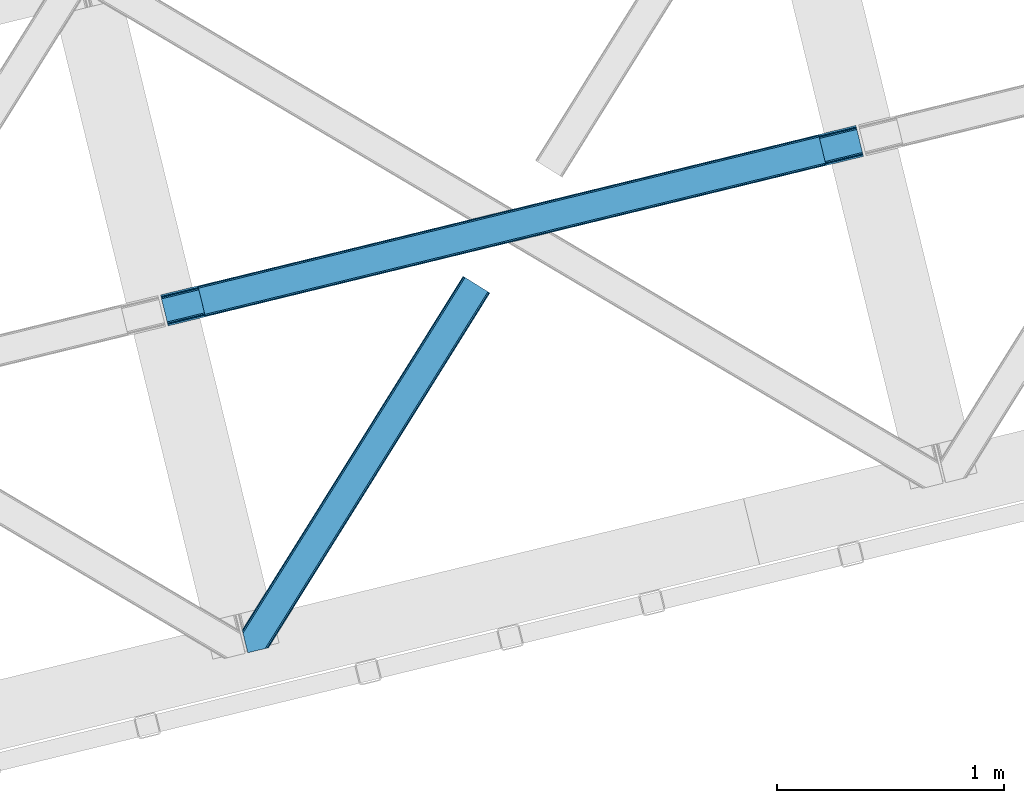
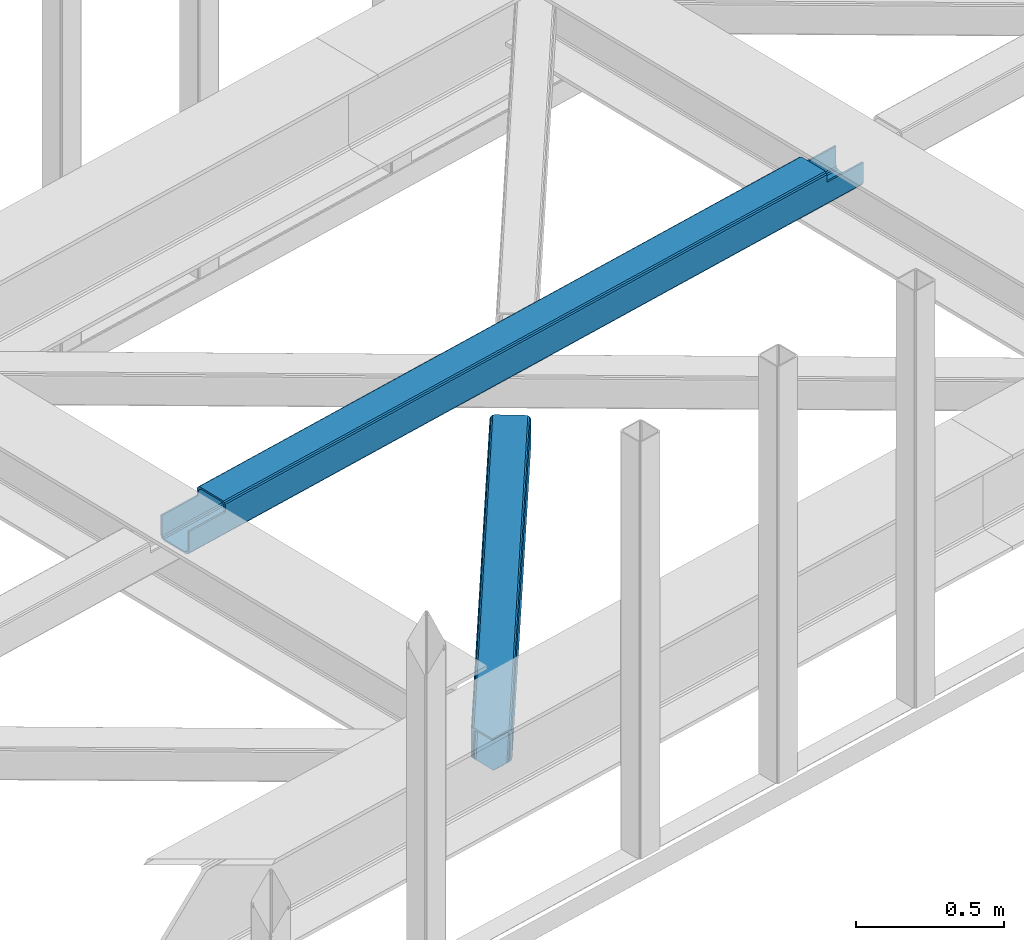
# One storey, part 42 of 66: 1 beam, 1 member.
"""IFC4 building model written with IfcOpenShell, lengths in millimetres."""

from ifc_helpers import new_model, entity, si_unit, converted_unit, derived_unit, direction, frame, origin, place, context, subcontext, project, spatial, triangles, polygons, material, type_object, element, save


model = new_model("IFC4")

# Units and contexts
model_context = context("Model", 3, precision=0.01, world=origin(), true_north=direction((6.12303176911189e-17, 1.0)))
plan_context = context("Plan", 3, precision=0.01, world=origin(), true_north=direction((6.12303176911189e-17, 1.0)))
body_context = subcontext(model_context, "Body", "Model", "MODEL_VIEW")
ifc_project = project(units=[si_unit("LENGTHUNIT", "METRE", prefix="MILLI"), si_unit("AREAUNIT", "SQUARE_METRE"), si_unit("VOLUMEUNIT", "CUBIC_METRE"), converted_unit("PLANEANGLEUNIT", "DEGREE", entity("IfcRatioMeasure", 0.0174532925199433), si_unit("PLANEANGLEUNIT", "RADIAN"), dimensions=[0, 0, 0, 0, 0, 0, 0]), si_unit("MASSUNIT", "GRAM", prefix="KILO"), derived_unit("MASSDENSITYUNIT", [(si_unit("MASSUNIT", "GRAM", prefix="KILO"), 1), (si_unit("LENGTHUNIT", "METRE"), -3)]), derived_unit("MOMENTOFINERTIAUNIT", [(si_unit("LENGTHUNIT", "METRE"), 4)]), si_unit("TIMEUNIT", "SECOND"), si_unit("FREQUENCYUNIT", "HERTZ"), si_unit("THERMODYNAMICTEMPERATUREUNIT", "DEGREE_CELSIUS"), derived_unit("THERMALTRANSMITTANCEUNIT", [(si_unit("MASSUNIT", "GRAM", prefix="KILO"), 1), (si_unit("THERMODYNAMICTEMPERATUREUNIT", "KELVIN"), -1), (si_unit("TIMEUNIT", "SECOND"), -3)]), derived_unit("VOLUMETRICFLOWRATEUNIT", [(si_unit("LENGTHUNIT", "METRE"), 3), (si_unit("TIMEUNIT", "SECOND"), -1)]), derived_unit("MASSFLOWRATEUNIT", [(si_unit("MASSUNIT", "GRAM", prefix="KILO"), 1), (si_unit("TIMEUNIT", "SECOND"), -1)]), derived_unit("ROTATIONALFREQUENCYUNIT", [(si_unit("TIMEUNIT", "SECOND"), -1)]), si_unit("ELECTRICCURRENTUNIT", "AMPERE"), si_unit("ELECTRICVOLTAGEUNIT", "VOLT"), si_unit("POWERUNIT", "WATT"), si_unit("FORCEUNIT", "NEWTON", prefix="KILO"), si_unit("ILLUMINANCEUNIT", "LUX"), si_unit("LUMINOUSFLUXUNIT", "LUMEN"), si_unit("LUMINOUSINTENSITYUNIT", "CANDELA"), derived_unit("USERDEFINED", [(si_unit("MASSUNIT", "GRAM", prefix="KILO"), -1), (si_unit("LENGTHUNIT", "METRE"), -2), (si_unit("TIMEUNIT", "SECOND"), 3), (si_unit("LUMINOUSFLUXUNIT", "LUMEN"), 1)]), derived_unit("LINEARVELOCITYUNIT", [(si_unit("LENGTHUNIT", "METRE"), 1), (si_unit("TIMEUNIT", "SECOND"), -1)]), si_unit("PRESSUREUNIT", "PASCAL"), derived_unit("USERDEFINED", [(si_unit("LENGTHUNIT", "METRE"), -2), (si_unit("MASSUNIT", "GRAM", prefix="KILO"), 1), (si_unit("TIMEUNIT", "SECOND"), -2)]), derived_unit("LINEARFORCEUNIT", [(si_unit("MASSUNIT", "GRAM", prefix="KILO"), 1), (si_unit("LENGTHUNIT", "METRE"), 1), (si_unit("TIMEUNIT", "SECOND"), -2), (si_unit("LENGTHUNIT", "METRE"), -1)]), derived_unit("PLANARFORCEUNIT", [(si_unit("MASSUNIT", "GRAM", prefix="KILO"), 1), (si_unit("LENGTHUNIT", "METRE"), 1), (si_unit("TIMEUNIT", "SECOND"), -2), (si_unit("LENGTHUNIT", "METRE"), -2)])], contexts=[model_context, plan_context])

# Site, building, storey
site_placement = place(None, origin())
site = spatial("IfcSite", under=ifc_project, at=site_placement, CompositionType="ELEMENT")
building_placement = place(site_placement, origin())
building = spatial("IfcBuilding", under=site, at=building_placement, CompositionType="ELEMENT")
storey_placement = place(building_placement, frame((0.0, 0.0, 19800.0)))
storey = spatial("IfcBuildingStorey", under=building, at=storey_placement, Name="06", CompositionType="ELEMENT", Elevation=19800.0)

# Beam
ifc_material = material(Name="Metal painted (White)")
beam_type = type_object("IfcBeamType", PredefinedType="BEAM")
beam_placement = place(storey_placement, frame((-23668.08, 13370.6, 3967.02)))
element("IfcBeam", 1, at=beam_placement, inside=storey, type_object=beam_type, material=ifc_material, ObjectType="Steel Beam", PredefinedType="BEAM", context=body_context, shape_type="Tessellation", body=[
    polygons([(31.1823923917571, 8.09507685196108, 17.8030399336114), (31.4978703677187, 6.80086440699217, 24.4999999999988), (3089.94374939707, 752.329405140572, 24.4999999999988), (3089.62827142112, 753.623617585543, 17.8030399336114), (30.2839871259035, 11.7806820741864, 12.1256313292298), (3088.72986615527, 757.309222807771, 12.1256313292298), (28.9394286278234, 17.2965800886753, 8.33210818105214), (3087.38530765718, 762.82512082226, 8.33210818105214), (27.3534137403861, 23.8030254244683, 7.00000000000274), (3085.79929276975, 769.331566158049, 7.00000000000274), (4.21622439082827, 118.720708051134, 8.33210818105214), (5.80223927826556, 112.214262715343, 7.00000000000274), (3064.24811830762, 857.742803448927, 7.00000000000274), (3062.66210342019, 864.249248784716, 8.33210818105214), (2.87166589274824, 124.236606065622, 12.1256313292342), (3061.31754492211, 869.765146799203, 12.1256313292342), (1.9732606268946, 127.922211287848, 17.8030399336114), (3060.41913965625, 873.450752021432, 17.8030399336114), (1.65778265093735, 129.216423732819, 24.4999999999988), (3060.10366168028, 874.744964466397, 24.4999999999988), (33.1556530186517, 2.16573425859679e-12, 17.5000000000004), (33.155653018656, 2.16573425859679e-12, 99.499999999999), (31.4978703677273, 6.80086440699434, 99.499999999999), (1.65778265094168, 129.216423732819, 99.499999999999), (1.29944055515807e-11, 136.017288139811, 99.499999999999), (8.66293703438714e-12, 136.017288139811, 17.5000000000004), (0.315477975970248, 134.72307569484, 10.803039933613), (1.21388324181955, 131.037470472615, 5.12563132923143), (2.55844173990391, 125.521572458126, 1.33210818105373), (4.14445662733688, 119.015127122335, 0.0), (29.0111963913235, 17.0021610174783, 0.0), (30.5972112787608, 10.4957156816875, 1.33210818105373), (31.9417697768408, 4.97981766719851, 5.12563132923576), (32.8401750426944, 1.29421244497107, 10.803039933613), (3058.44587902935, 881.545828873387, 17.5000000000004), (3058.44587902935, 881.545828873387, 99.499999999999), (3060.10366168027, 874.744964466395, 99.499999999999), (3089.94374939706, 752.32940514057, 99.499999999999), (3091.60153204799, 745.52854073358, 99.499999999999), (3091.60153204799, 745.52854073358, 17.5000000000004), (3091.28605407204, 746.822753178549, 10.803039933613), (3090.38764880618, 750.508358400772, 5.12563132923576), (3089.0430903081, 756.024256415263, 1.33210818105373), (3087.45707542067, 762.530701751056, 0.0), (3062.59033565668, 864.543667855911, 0.0), (3061.00432076925, 871.050113191702, 1.33210818105373), (3059.65976227116, 876.566011206191, 5.12563132923143), (3058.76135700531, 880.251616428418, 10.803039933613), (2925.75994180944, 712.307865540887, 115.5000123926), (2925.8163098943, 712.321604759503, 100.117303289864), (2926.72300362931, 712.542621518197, 99.499999999999), (194.718606580809, 46.58768115868, 99.5063429816656), (195.631369831921, 46.8101414945073, 100.117301735448), (195.690168193635, 46.8244741223611, 115.5), (2928.38078628024, 705.741757111205, 99.499999999999), (2927.47422618799, 705.520772937698, 100.117303484932), (2927.41464342032, 705.506249905356, 122.500007895425), (197.345360928056, 40.0229783796067, 122.500002534479), (197.338587096745, 40.0213271441479, 100.500009163303), (196.748205195729, 39.8773799905087, 99.5697919021647), (2896.88292546721, 834.958147714716, 99.5063429816656), (2895.97381660775, 834.736577552001, 100.117299778624), (2895.91744852288, 834.722838333383, 115.50000888136), (165.85008047685, 169.240033448183, 115.5), (165.840462203347, 169.237688832044, 100.50000941238), (165.250325295037, 169.093836777333, 99.5761204674868), (2894.8533268523, 841.668448882887, 99.5697919021647), (163.220745767778, 175.804071762186, 99.499999999999), (164.133244938523, 176.026503182401, 100.117301984524), (164.189439987641, 176.04020120897, 122.500002796667), (2894.25631754638, 841.522886341466, 122.500003994045), (2894.2664208352, 841.525349756033, 100.500018741102), (2894.56843170076, 840.227853719303, 129.196959150505), (2895.46176722634, 836.541012377608, 134.874360354937), (2896.80305823041, 831.024317672804, 138.667878733795), (2898.38810531641, 824.517636364728, 139.999985502214), (2923.25885436335, 722.505647815416, 139.999991354283), (2924.84634848093, 715.999563150013, 138.667885332354), (2926.19460804137, 710.484567539782, 134.874367586349), (2927.09837274858, 706.800269072832, 129.196966804773), (2925.44675217774, 713.602635936904, 122.196975799125), (2924.54298747052, 717.286934403861, 127.874376580702), (2923.19472791009, 722.801930014085, 131.667894326702), (2921.6072337925, 729.30801467949, 133.000000348631), (2900.0525846185, 817.718404755559, 132.999995276841), (2898.46753753249, 824.225086063634, 131.667888508414), (2897.12624652842, 829.741780768443, 127.874370129564), (2896.23291100283, 833.428622110133, 122.196968925133), (164.878528418711, 169.003207355196, 99.499999999999), (193.13172645374, 57.3201898040421, 131.667891818946), (191.545711566303, 63.8266351398372, 133.0), (194.476284951825, 51.8042917895531, 127.874368670764), (195.374690217678, 48.11868656733, 122.196960066391), (169.994537104182, 152.237872430714, 133.0), (166.165558452811, 167.945821003219, 122.196960066391), (167.063963718665, 164.260215780994, 127.874368670764), (168.408522216745, 158.744317766505, 131.667891818946), (197.031411944082, 41.3175635421181, 129.196961104604), (196.136488323074, 45.0040174739024, 134.874366301861), (194.794244157323, 50.5204796458751, 138.667887185257), (193.209023953591, 57.0271186992037, 139.999994588639), (168.341882306945, 159.039986838394, 139.999994981919), (166.755021471193, 165.546225960036, 138.667887628704), (165.408105180739, 171.061549222932, 134.874366787843), (164.506189230969, 174.746298656828, 129.196961619)], [[[1, 2, 3, 4]], [[5, 1, 4, 6]], [[7, 5, 6, 8]], [[9, 7, 8, 10]], [[11, 12, 13, 14]], [[15, 11, 14, 16]], [[17, 15, 16, 18]], [[19, 17, 18, 20]], [[12, 9, 10, 13]], [[21, 22, 23, 2, 1, 5, 7, 9, 12, 11, 15, 17, 19, 24, 25, 26, 27, 28, 29, 30, 31, 32, 33, 34]], [[35, 36, 37, 20, 18, 16, 14, 13, 10, 8, 6, 4, 3, 38, 39, 40, 41, 42, 43, 44, 45, 46, 47, 48]], [[49, 50, 51, 38, 3, 2, 23, 52, 53, 54]], [[55, 39, 38, 51]], [[39, 55, 56, 57, 58, 59, 60, 22, 21, 40]], [[32, 31, 44, 43]], [[33, 32, 43, 42]], [[34, 33, 42, 41]], [[21, 34, 41, 40]], [[31, 30, 45, 44]], [[27, 26, 35, 48]], [[28, 27, 48, 47]], [[29, 28, 47, 46]], [[30, 29, 46, 45]], [[20, 37, 61, 62, 63, 64, 65, 66, 24, 19]], [[67, 36, 35, 26, 25, 68, 69, 70, 71, 72]], [[36, 67, 61, 37]], [[72, 71, 73, 74, 75, 76, 77, 78, 79, 80, 57, 56, 50, 49, 81, 82, 83, 84, 85, 86, 87, 88, 63, 62]], [[60, 52, 23, 22]], [[25, 24, 89, 68]], [[90, 91, 84, 83]], [[92, 90, 83, 82]], [[93, 92, 82, 81]], [[54, 93, 81, 49]], [[94, 85, 84, 91]], [[95, 64, 63, 88]], [[96, 95, 88, 87]], [[97, 96, 87, 86]], [[94, 97, 86, 85]], [[65, 64, 95, 96, 97, 94, 91, 90, 92, 93, 54, 53, 59, 58, 98, 99, 100, 101, 102, 103, 104, 105, 70, 69]], [[98, 58, 57, 80]], [[99, 98, 80, 79]], [[100, 99, 79, 78]], [[101, 100, 78, 77]], [[77, 76, 102, 101]], [[103, 102, 76, 75]], [[104, 103, 75, 74]], [[105, 104, 74, 73]], [[70, 105, 73, 71]]], closed=False),
])

# Member
member_type = type_object("IfcMemberType", PredefinedType="BRACE")
member_placement = place(storey_placement, frame((-23308.99, 11932.7, 3823.0)))
element("IfcMember", 2, at=member_placement, inside=storey, type_object=member_type, ObjectType="Steel Horizontal Brace", PredefinedType="BRACE", context=body_context, shape_type="Tessellation", body=[
    triangles([(986.153759765624, 1647.42967529297, 0.0), (1075.22274169922, 1591.82725524902, 0.0), (119.790362548825, 259.603921508789, 0.0), (154.551031494138, 117.003323364257, 0.0), (115.904553222656, 275.544808959961, 4.52065429687718), (117.571893310545, 268.698715209961, 1.33247680664135), (158.436840820312, 101.062435913085, 4.52065429687718), (156.767175292967, 107.908529663086, 1.33247680664135), (114.825549316403, 275.742471313477, 5.52059326172093), (115.132507324219, 275.92385559082, 5.35316162109302), (158.132208251951, 99.1218566894531, 5.27642211914281), (115.441790771481, 276.107565307617, 5.18107910156323), (158.234527587891, 99.7776306152336, 5.02062377929906), (158.190344238279, 99.4822998046875, 5.13457031250073), (115.544110107421, 276.168026733398, 5.12526855468968), (115.68596191406, 275.921530151367, 4.88574829101708), (158.336846923827, 100.433404541016, 4.76482543945531), (158.032214355466, 98.4928253173821, 5.52059326172093), (1085.71977539062, 1585.27416687012, 5.12526855468968), (1080.9037902832, 1588.28096008301, 1.33247680664135), (1088.93818359375, 1583.26498718262, 10.8039916992202), (114.21163330078, 21.8533172607422, 10.8039916992202), (109.467736816405, 20.6964111328125, 5.52059326172093), (1090.06834716797, 1582.55921630859, 17.5012573242202), (116.062683105469, 22.3044525146488, 17.5012573242202), (6.75307617187354, 102.619317626953, 5.52059326172093), (31.3655273437471, 1.65803833007885, 5.52059326172093), (1090.06834716797, 1582.55921630859, 122.499499511719), (116.062683105469, 22.3044525146488, 122.499499511719), (1088.93818359375, 1583.26498718262, 129.196765136719), (114.21163330078, 21.8533172607422, 129.196765136719), (1085.71977539062, 1585.27416687012, 134.87548828125), (108.937536621092, 20.5673492431633, 134.87548828125), (1080.9037902832, 1588.28096008301, 138.668280029298), (101.042669677732, 18.6430480957024, 138.668280029298), (1075.22274169922, 1591.82725524902, 140.00075683594), (91.7292846679666, 16.3722564697273, 140.00075683594), (980.472711181639, 1650.97597045899, 1.33247680664135), (975.656726074216, 1653.98276367187, 5.12526855468968), (1.69059448242115, 100.410150146485, 10.9621215820334), (972.438317871092, 1655.99078063965, 10.8039916992202), (971.310479736327, 1656.69655151367, 17.5012573242202), (0.239520263668965, 99.7776306152336, 12.5201660156272), (0.0, 100.760128784179, 17.5012573242202), (5.79266967773219, 76.992974853516, 140.00075683594), (986.153759765624, 1647.42967529297, 140.00075683594), (24.5612915039055, 0.0, 140.00075683594), (971.310479736327, 1656.69655151367, 122.499499511719), (0.0, 100.760128784179, 122.499499511719), (980.472711181639, 1650.97597045899, 138.668280029298), (3.57652587890334, 86.0889312744148, 138.668280029298), (975.656726074216, 1653.98276367187, 134.87548828125), (1.69757080078125, 93.7989257812496, 134.87548828125), (972.438317871092, 1655.99078063965, 129.196765136719), (0.44183349609375, 98.9509368896488, 129.196765136719), (29.9260803222642, 1.30689697265552, 6.99957275390625), (12.1969299316406, 74.0326904296871, 6.99957275390625), (8.99479980468459, 81.5485107421882, 8.3320495605476), (3.88813476562427, 84.8122650146488, 12.5201660156272), (1069.28356933594, 1595.53400573731, 6.99957275390625), (81.9973205566384, 14.0003082275398, 6.99957275390625), (992.092932128904, 1643.72292480469, 6.99957275390625), (981.593572998045, 1650.27485046387, 12.1248413085959), (978.379815673827, 1652.28519287109, 17.8035644531265), (2.75797119140407, 89.4445404052731, 17.8035644531265), (986.409558105468, 1647.26805725098, 8.3320495605476), (977.245001220701, 1652.98863830566, 24.5008300781265), (2.3184631347649, 91.2537322998051, 24.5008300781265), (977.245001220701, 1652.98863830566, 115.499926757813), (2.3184631347649, 91.2537322998051, 115.499926757813), (4.01370849609157, 84.2925292968757, 127.873590087893), (2.75797119140407, 89.4445404052731, 122.197192382813), (5.89498901367188, 76.5813720703118, 131.668707275392), (8.11113281249709, 67.4865783691403, 133.001184082033), (24.5612915039055, 0.0, 133.001184082033), (978.379815673827, 1652.28519287109, 122.197192382813), (981.593572998045, 1650.27485046387, 127.873590087893), (986.409558105468, 1647.26805725098, 131.668707275392), (992.092932128904, 1643.72292480469, 133.001184082033), (1069.28356933594, 1595.53400573731, 133.001184082033), (81.9973205566384, 14.0003082275398, 133.001184082033), (1079.78060302734, 1588.9809173584, 12.1248413085959), (1082.99901123047, 1586.9717376709, 17.8035644531265), (1084.12917480469, 1586.26596679687, 24.5008300781265), (1074.96461791992, 1591.98654785156, 8.3320495605476), (1079.78060302734, 1588.9809173584, 127.873590087893), (1084.12917480469, 1586.26596679687, 115.499926757813), (1082.99901123047, 1586.9717376709, 122.197192382813), (1074.96461791992, 1591.98654785156, 131.668707275392), (91.3107055664041, 16.2699371337894, 131.668707275392), (99.2032470703125, 18.1942382812504, 127.873590087893), (104.479669189452, 19.4802062988274, 122.197192382813), (106.330718994141, 19.931341552734, 115.499926757813), (91.3107055664041, 16.2699371337894, 8.3320495605476), (104.479669189452, 19.4802062988274, 17.8035644531265), (99.2032470703125, 18.1942382812504, 12.1248413085959), (106.330718994141, 19.931341552734, 24.5008300781265)], [[1, 2, 3], [4, 3, 2], [5, 3, 4], [3, 5, 6], [4, 7, 5], [7, 4, 8], [9, 10, 11], [10, 12, 13], [13, 14, 10], [12, 15, 16], [16, 17, 12], [16, 5, 7], [7, 17, 16], [17, 13, 12], [14, 11, 10], [11, 18, 9], [19, 14, 13], [13, 20, 19], [13, 17, 20], [17, 7, 20], [7, 8, 20], [21, 22, 18], [18, 19, 21], [14, 19, 11], [18, 11, 19], [22, 23, 18], [21, 24, 25], [25, 22, 21], [2, 20, 4], [8, 4, 20], [23, 26, 18], [23, 27, 26], [9, 18, 26], [24, 28, 29], [29, 25, 24], [28, 30, 29], [31, 29, 30], [30, 32, 31], [33, 31, 32], [32, 34, 33], [35, 33, 34], [34, 36, 35], [37, 35, 36], [38, 6, 5], [5, 39, 38], [5, 15, 39], [40, 41, 9], [41, 39, 15], [42, 41, 40], [40, 43, 42], [43, 44, 42], [9, 26, 40], [38, 1, 6], [3, 6, 1], [36, 45, 37], [36, 46, 45], [45, 47, 37], [48, 42, 44], [44, 49, 48], [46, 50, 51], [51, 45, 46], [50, 52, 53], [53, 51, 50], [52, 54, 55], [55, 53, 52], [54, 48, 49], [49, 55, 54], [27, 56, 57], [26, 57, 58], [57, 26, 27], [59, 40, 26], [26, 58, 59], [43, 40, 59], [60, 57, 61], [60, 62, 57], [57, 56, 61], [63, 64, 65], [65, 59, 63], [66, 63, 59], [62, 66, 58], [58, 57, 62], [59, 58, 66], [64, 67, 68], [68, 65, 64], [67, 69, 70], [70, 68, 67], [71, 53, 72], [73, 74, 45], [74, 47, 45], [74, 75, 47], [51, 73, 45], [71, 51, 53], [71, 73, 51], [49, 68, 70], [55, 72, 53], [70, 72, 49], [72, 55, 49], [44, 68, 49], [43, 59, 65], [65, 68, 44], [44, 43, 65], [69, 76, 70], [72, 70, 76], [76, 77, 72], [71, 72, 77], [77, 78, 71], [73, 71, 78], [78, 79, 73], [74, 73, 79], [80, 74, 79], [74, 80, 81], [75, 74, 81], [21, 82, 83], [84, 28, 24], [21, 83, 24], [21, 19, 82], [83, 84, 24], [82, 19, 20], [60, 2, 1], [2, 85, 20], [85, 2, 60], [85, 82, 20], [30, 86, 32], [87, 28, 84], [28, 88, 30], [88, 28, 87], [30, 88, 86], [36, 80, 46], [34, 32, 86], [86, 89, 34], [89, 80, 36], [36, 34, 89], [63, 38, 39], [1, 62, 60], [1, 66, 62], [66, 1, 38], [63, 66, 38], [67, 42, 48], [41, 64, 63], [39, 41, 63], [64, 41, 42], [67, 64, 42], [50, 77, 52], [46, 80, 79], [79, 78, 46], [78, 77, 50], [50, 46, 78], [54, 52, 77], [48, 69, 67], [76, 48, 54], [48, 76, 69], [76, 54, 77], [35, 37, 90], [47, 81, 37], [81, 47, 75], [81, 90, 37], [91, 35, 90], [91, 33, 35], [33, 92, 31], [92, 33, 91], [29, 92, 93], [92, 29, 31], [61, 23, 94], [95, 96, 23], [96, 94, 23], [61, 27, 23], [27, 61, 56], [97, 95, 25], [22, 25, 95], [29, 97, 25], [97, 29, 93], [95, 23, 22], [80, 89, 90], [90, 81, 80], [89, 86, 91], [91, 90, 89], [86, 88, 92], [92, 91, 86], [88, 87, 93], [93, 92, 88], [87, 84, 93], [97, 93, 84], [84, 83, 97], [95, 97, 83], [83, 82, 95], [96, 95, 82], [82, 85, 96], [94, 96, 85], [85, 60, 94], [61, 94, 60]]),
])

save(model, "model.ifc")
